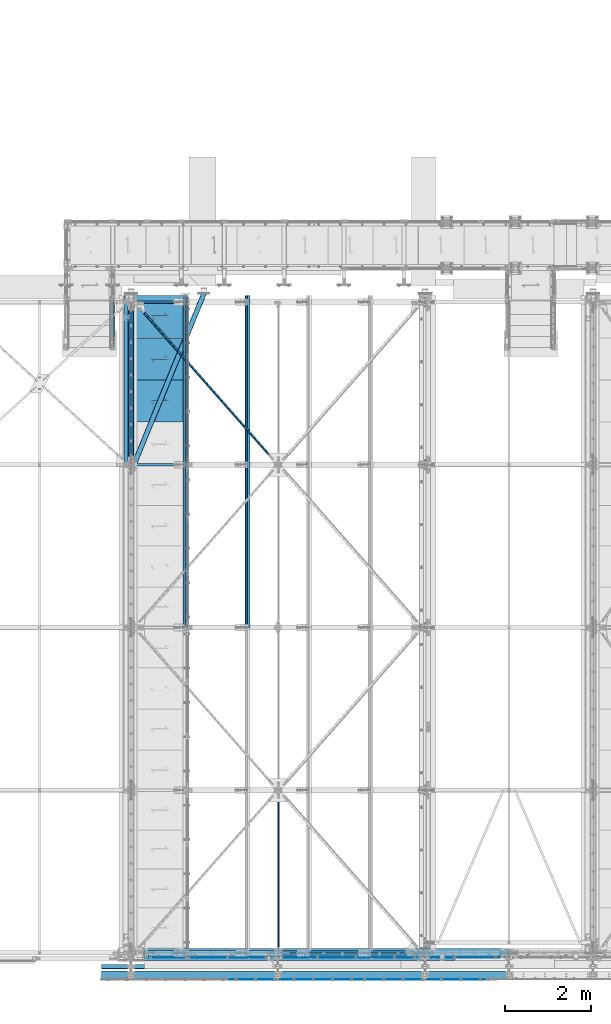
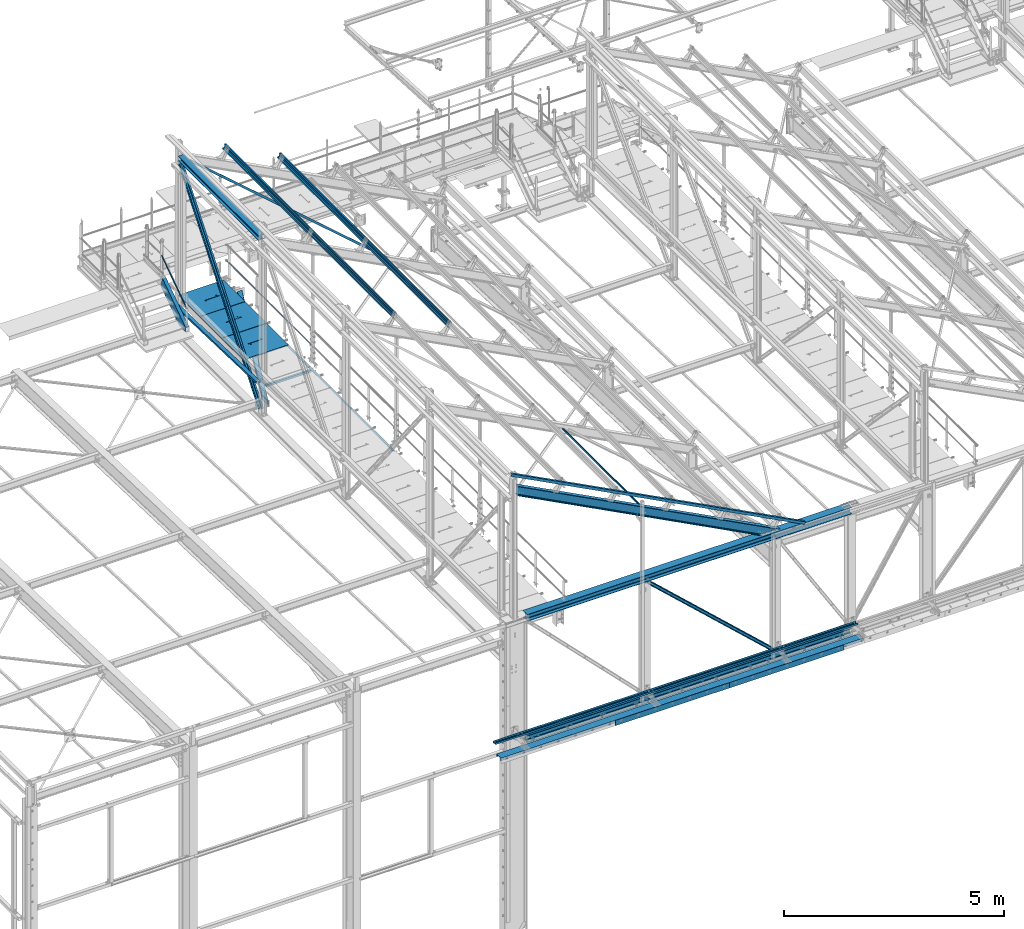
# One storey, part 46 of 496: 22 beams, 8 members, 30 elements without a shape of their own.
"""IFC2X3 building model written with IfcOpenShell, lengths in millimetres."""

from ifc_helpers import new_model, si_unit, frame, origin_with_axes, origin_2d_with_axis, place, context, subcontext, project, spatial, polyline, rectangle, hollow_rectangle, hollow_circle, i_section, l_section, u_section, outline, extrude, boolean, clip, halfspace, material, type_object, element, aggregate, save


model = new_model("IFC2X3")

# Units and contexts
model_context = context("Model", 3, precision=1e-05, world=origin_with_axes())
body_context = subcontext(model_context, "Body", "Model", "MODEL_VIEW")
ifc_project = project(units=[si_unit("LENGTHUNIT", "METRE", prefix="MILLI"), si_unit("AREAUNIT", "SQUARE_METRE"), si_unit("VOLUMEUNIT", "CUBIC_METRE"), si_unit("MASSUNIT", "GRAM", prefix="KILO"), si_unit("TIMEUNIT", "SECOND"), si_unit("PLANEANGLEUNIT", "RADIAN"), si_unit("SOLIDANGLEUNIT", "STERADIAN"), si_unit("THERMODYNAMICTEMPERATUREUNIT", "DEGREE_CELSIUS"), si_unit("LUMINOUSINTENSITYUNIT", "LUMEN")], contexts=[model_context])

# Site, building, storey
site_placement = place(None, origin_with_axes())
site = spatial("IfcSite", under=ifc_project, at=site_placement, CompositionType="ELEMENT")
building_placement = place(site_placement, origin_with_axes())
building = spatial("IfcBuilding", under=site, at=building_placement, Name="Undefined", CompositionType="ELEMENT")
storey_placement = place(building_placement, origin_with_axes())
storey = spatial("IfcBuildingStorey", under=building, at=storey_placement, Name="Undefined", CompositionType="ELEMENT", Elevation=0.0)

# Assembly, member
assembly_1_placement = place(storey_placement, origin_with_axes())
assembly_1 = element("IfcElementAssembly", 1, at=assembly_1_placement, inside=storey, Name="MAIN COURANTE", AssemblyPlace="NOTDEFINED", PredefinedType="NOTDEFINED")
ifc_material_1 = material(Name="Undefined/S235-E24")
member_type_1 = type_object("IfcMemberType", PredefinedType="NOTDEFINED")
member_1_placement = place(assembly_1_placement, frame((12269.9936634988, 14144.9998536997, 8651.13839395851), z_axis=(0.999999999999672, -6.66011674184119e-07, -4.61008081401814e-07), x_axis=(0.0, 0.822192191679776, 0.569209978778312)))
member_1 = element("IfcMember", 2, at=member_1_placement, type_object=member_type_1, material=ifc_material_1, Name="LISSE", context=body_context, shape_type="Clipping", body=[
    clip(clip(extrude(hollow_circle(Radius=10.64999962, WallThickness=2.0, at=origin_2d_with_axis()), frame((1395.35433691202, -1.13686837721616e-12, 7.38694435286663e-20), z_axis=(-1.0, 0.0, 0.0), x_axis=(0.0, -1.0, 0.0)), (0.0, 0.0, 1.0), 1404.17), halfspace(frame((1387.78549896895, 10.5802584847568, -0.00112410556903342), z_axis=(-0.822192191679508, 0.569209978778309, 6.66011673795452e-07), x_axis=(-0.569209978778123, -0.822192191679778, 4.61008086858783e-07)), True)), halfspace(frame((16.4615054726892, 14.9935154708171, -1.33328576339409e-05), z_axis=(0.822192191679509, -0.569209978778308, -6.66011673277761e-07), x_axis=(0.0, 0.0, -1.0)), True)),
])
aggregate(assembly_1, [member_1])

# Assembly, beam
assembly_2_placement = place(storey_placement, origin_with_axes())
assembly_2 = element("IfcElementAssembly", 3, at=assembly_2_placement, inside=storey, Name="SUPPORT", AssemblyPlace="NOTDEFINED", PredefinedType="NOTDEFINED")
beam_type_1 = type_object("IfcBeamType", PredefinedType="NOTDEFINED")
beam_1_placement = place(assembly_2_placement, frame((13921.4998855121, 15280.0000894508, 8074.99999999999), z_axis=(-1.0, 0.0, 0.0), x_axis=(0.0, -1.0, 0.0)))
beam_1 = element("IfcBeam", 4, at=beam_1_placement, type_object=beam_type_1, material=ifc_material_1, Name="SUPPORT", context=body_context, shape_type="SweptSolid", body=[
    extrude(l_section(Depth=50.0, Width=50.0, Thickness=5.0, FilletRadius=7.0, EdgeRadius=3.5, at=origin_2d_with_axis()), frame((7675.0000889974, 0.0, 0.0), z_axis=(-1.0, 0.0, 0.0), x_axis=(0.0, -1.0, 0.0)), (0.0, 0.0, 1.0), 7675.0),
])
aggregate(assembly_2, [beam_1])

# Assembly, member
assembly_3_placement = place(storey_placement, origin_with_axes())
assembly_3 = element("IfcElementAssembly", 5, at=assembly_3_placement, inside=storey, AssemblyPlace="NOTDEFINED", PredefinedType="NOTDEFINED")
ifc_material_2 = material(Name="Undefined/S275-E28")
member_type_2 = type_object("IfcMemberType", Name="UPN260", PredefinedType="NOTDEFINED")
member_2_placement = place(assembly_3_placement, frame((12254.9957050653, 15220.1081967775, 8803.11488296132), z_axis=(-2.38199999876088e-06, 0.569209978780056, -0.822192191675118), x_axis=(-8.09999997507615e-07, -0.822192191679509, -0.569209978778121)))
member_2 = element("IfcMember", 6, at=member_2_placement, type_object=member_type_2, material=ifc_material_2, ObjectType="UPN260", context=body_context, shape_type="Clipping", body=[
    clip(clip(clip(extrude(u_section(Depth=260.0, FlangeWidth=90.0, WebThickness=10.0, FlangeThickness=14.0, FilletRadius=14.0, EdgeRadius=7.0, FlangeSlope=0.0798299857122373, at=origin_2d_with_axis()), frame((1532.05974941516, 3.24426271229202e-19, 1.50656932765752e-12), z_axis=(-1.0, 0.0, 0.0), x_axis=(0.0, -1.0, 0.0)), (0.0, 0.0, 1.0), 1652.65), halfspace(frame((1475.10561376755, -44.9999999999982, -130.0), z_axis=(0.594754891759256, -2.93590080272386e-06, 0.803907095826263), x_axis=(-0.803907095829728, -3.97667463540568e-10, 0.594754891761819)), False)), halfspace(frame((1280.85769771495, 106.407624448384, -129.999853684547), z_axis=(-0.822192191678566, 5.58458236969981e-08, 0.569209978780058), x_axis=(0.569209978777471, -2.93579533354204e-06, 0.822192191675117)), True)), halfspace(frame((81.2187427422505, 545.001446996483, 130.001191003446), z_axis=(0.954513538741863, -9.28664575673263e-07, -0.298167577643218), x_axis=(1.71699999918928e-06, 0.999999999995689, 2.38199999876088e-06)), True)),
])
aggregate(assembly_3, [member_2])

# Assembly, beam
assembly_4_placement = place(storey_placement, origin_with_axes())
assembly_4 = element("IfcElementAssembly", 7, at=assembly_4_placement, inside=storey, AssemblyPlace="NOTDEFINED", PredefinedType="NOTDEFINED")
beam_type_2 = type_object("IfcBeamType", PredefinedType="NOTDEFINED")
beam_2_placement = place(assembly_4_placement, frame((12780.6286044855, 15197.8852381123, 12052.4067909321), z_axis=(0.628485342577473, 0.704921080203063, -0.328774154778966), x_axis=(0.624617904868394, -0.709285746850553, -0.32675097893116)))
beam_2 = element("IfcBeam", 8, at=beam_2_placement, type_object=beam_type_2, material=ifc_material_1, context=body_context, shape_type="Clipping", body=[
    clip(clip(extrude(l_section(Depth=60.0, Width=60.0, Thickness=6.0, FilletRadius=8.0, EdgeRadius=4.0, at=origin_2d_with_axis()), frame((5268.62284058304, 0.0, -2.92467319284064e-13), z_axis=(-1.0, 0.0, 0.0), x_axis=(0.0, -1.0, 0.0)), (0.0, 0.0, 1.0), 5179.74), halfspace(frame((5188.72404710403, 30.0000006031805, -30.0000000072323), z_axis=(1.0, 0.0, 0.0), x_axis=(0.0, -1.0, 0.0)), False)), halfspace(frame((168.778125634137, 30.0000272725665, 30.0000000280488), z_axis=(-1.0, 0.0, 0.0), x_axis=(0.0, -1.0, 0.0)), False)),
])
aggregate(assembly_4, [beam_2])

assembly_5_placement = place(storey_placement, origin_with_axes())
assembly_5 = element("IfcElementAssembly", 9, at=assembly_5_placement, inside=storey, Name="SUPPORT", AssemblyPlace="NOTDEFINED", PredefinedType="NOTDEFINED")
beam_type_3 = type_object("IfcBeamType", PredefinedType="NOTDEFINED")
beam_3_placement = place(assembly_5_placement, frame((17989.9999880566, -622.0, 5154.99824538435), z_axis=(0.0, 0.0, 1.0), x_axis=(1.0, 0.0, 0.0)))
beam_3 = element("IfcBeam", 10, at=beam_3_placement, type_object=beam_type_3, material=ifc_material_1, Name="SUPPORT", context=body_context, shape_type="SweptSolid", body=[
    extrude(rectangle(XDim=4.0, YDim=150.0, at=origin_2d_with_axis()), frame((2999.99999402831, 0.0, 0.0), z_axis=(-1.0, 0.0, 0.0), x_axis=(0.0, -1.0, 0.0)), (0.0, 0.0, 1.0), 3000.0),
])
aggregate(assembly_5, [beam_3])

assembly_6_placement = place(storey_placement, origin_with_axes())
assembly_6 = element("IfcElementAssembly", 11, at=assembly_6_placement, inside=storey, Name="SUPPORT", AssemblyPlace="NOTDEFINED", PredefinedType="NOTDEFINED")
beam_4_placement = place(assembly_6_placement, frame((14989.9999940283, -622.0, 5154.99824538435), z_axis=(0.0, 0.0, 1.0), x_axis=(1.0, 0.0, 0.0)))
beam_4 = element("IfcBeam", 12, at=beam_4_placement, type_object=beam_type_3, material=ifc_material_1, Name="SUPPORT", context=body_context, shape_type="SweptSolid", body=[
    extrude(rectangle(XDim=4.0, YDim=150.0, at=origin_2d_with_axis()), frame((2999.99999402831, 0.0, 0.0), z_axis=(-1.0, 0.0, 0.0), x_axis=(0.0, -1.0, 0.0)), (0.0, 0.0, 1.0), 3000.0),
])
aggregate(assembly_6, [beam_4])

assembly_7_placement = place(storey_placement, origin_with_axes())
assembly_7 = element("IfcElementAssembly", 13, at=assembly_7_placement, inside=storey, Name="SUPPORT", AssemblyPlace="NOTDEFINED", PredefinedType="NOTDEFINED")
beam_type_4 = type_object("IfcBeamType", PredefinedType="NOTDEFINED")
beam_5_placement = place(assembly_7_placement, frame((21504.9999940283, -320.0, 5474.99824538435), z_axis=(0.0, -1.0, 0.0), x_axis=(-1.0, 0.0, 0.0)))
beam_5 = element("IfcBeam", 14, at=beam_5_placement, type_object=beam_type_4, material=ifc_material_1, Name="SUPPORT", context=body_context, shape_type="SweptSolid", body=[
    extrude(u_section(Depth=100.0, FlangeWidth=50.0, WebThickness=4.0, FlangeThickness=4.0, at=origin_2d_with_axis()), frame((9514.99999402831, 0.0, 0.0), z_axis=(-1.0, 0.0, 0.0), x_axis=(0.0, -1.0, 0.0)), (0.0, 0.0, 1.0), 9515.0),
])
aggregate(assembly_7, [beam_5])

assembly_8_placement = place(storey_placement, origin_with_axes())
assembly_8 = element("IfcElementAssembly", 15, at=assembly_8_placement, inside=storey, Name="LISSE", AssemblyPlace="NOTDEFINED", PredefinedType="NOTDEFINED")
beam_6_placement = place(assembly_8_placement, frame((12563.5000000142, 11402.9585391484, 8171.89575101457), z_axis=(1.0, 0.0, 0.0), x_axis=(0.0, 0.999506445341009, -0.0314144190107172)))
beam_6 = element("IfcBeam", 16, at=beam_6_placement, type_object=beam_type_4, material=ifc_material_1, Name="LISSE", context=body_context, shape_type="Clipping", body=[
    clip(extrude(u_section(Depth=100.0, FlangeWidth=50.0, WebThickness=4.0, FlangeThickness=4.0, at=origin_2d_with_axis()), frame((3989.01014791664, 0.0, 0.0), z_axis=(-1.0, 0.0, 0.0), x_axis=(0.0, -1.0, 0.0)), (0.0, 0.0, 1.0), 3989.01), halfspace(frame((3959.78106204689, -24.99999999994, -50.0), z_axis=(0.999506472307554, 0.0314135610096964, 0.0), x_axis=(0.0, 0.0, 1.0)), False)),
])
aggregate(assembly_8, [beam_6])

assembly_9_placement = place(storey_placement, origin_with_axes())
assembly_9 = element("IfcElementAssembly", 17, at=assembly_9_placement, inside=storey, Name="SUPPORT", AssemblyPlace="NOTDEFINED", PredefinedType="NOTDEFINED")
beam_type_5 = type_object("IfcBeamType", Name="UPN200", PredefinedType="NOTDEFINED")
beam_7_placement = place(assembly_9_placement, frame((11990.0, -520.0, 5192.49824538435), z_axis=(0.0, -1.0, 0.0), x_axis=(1.0, 0.0, 0.0)))
beam_7 = element("IfcBeam", 18, at=beam_7_placement, type_object=beam_type_5, material=ifc_material_2, Name="SUPPORT", ObjectType="UPN200", context=body_context, shape_type="SweptSolid", body=[
    extrude(u_section(Depth=200.0, FlangeWidth=75.0, WebThickness=8.5, FlangeThickness=11.5, FilletRadius=11.5, EdgeRadius=6.0, FlangeSlope=0.0798299857122373, at=origin_2d_with_axis()), frame((9514.99999402831, 0.0, 0.0), z_axis=(-1.0, 0.0, 0.0), x_axis=(0.0, -1.0, 0.0)), (0.0, 0.0, 1.0), 9515.0),
])
aggregate(assembly_9, [beam_7])

assembly_10_placement = place(storey_placement, origin_with_axes())
assembly_10 = element("IfcElementAssembly", 19, at=assembly_10_placement, inside=storey, Name="SUPPORT", AssemblyPlace="NOTDEFINED", PredefinedType="NOTDEFINED")
beam_type_6 = type_object("IfcBeamType", PredefinedType="NOTDEFINED")
beam_8_placement = place(assembly_10_placement, frame((13095.0012593194, -105.0, 5040.00085614788), z_axis=(0.0, 0.0, 1.0), x_axis=(1.0, 0.0, 0.0)))
beam_8 = element("IfcBeam", 20, at=beam_8_placement, type_object=beam_type_6, material=ifc_material_1, Name="SUPPORT", context=body_context, shape_type="SweptSolid", body=[
    extrude(rectangle(XDim=10.0, YDim=80.0, at=origin_2d_with_axis()), frame((8194.99874155635, -2.1691981052518e-19, 0.0), z_axis=(-1.0, 0.0, 0.0), x_axis=(0.0, -1.0, 0.0)), (0.0, 0.0, 1.0), 8195.0),
])
aggregate(assembly_10, [beam_8])

assembly_11_placement = place(storey_placement, origin_with_axes())
assembly_11 = element("IfcElementAssembly", 21, at=assembly_11_placement, inside=storey, AssemblyPlace="NOTDEFINED", PredefinedType="NOTDEFINED")
beam_type_7 = type_object("IfcBeamType", PredefinedType="NOTDEFINED")
beam_9_placement = place(assembly_11_placement, frame((13936.4998764003, 15354.9999809229, 8115.0), z_axis=(0.0, 0.0, 1.0), x_axis=(-1.0, 0.0, 0.0)))
beam_9 = element("IfcBeam", 22, at=beam_9_placement, type_object=beam_type_7, material=ifc_material_1, context=body_context, shape_type="CSG", body=[
    boolean("DIFFERENCE", extrude(outline(polyline([(0.0, 0.0), (1179.99169921875, 0.0), (1179.99169921875, 980.0), (-9.39995516091585e-07, 980.0), (0.0, 0.0)])), frame((0.0, 0.0, -15.0), z_axis=(0.0, 0.0, 1.0), x_axis=(1.0, 0.0, 0.0)), (0.0, 0.0, 1.0), 30.0), extrude(outline(polyline([(0.0, 0.0), (9.99999999997453, 6.91215973347425e-11), (10.0000000004329, 75.8578643791443), (282.842712400121, -196.984848017997), (282.842712400743, -96.9848480190813), (272.842712400776, -96.9848480191613), (272.842712400299, -172.842712398218), (0.0, 100.0), (0.0, 0.0)])), frame((724.286946489367, 555.710676888644, -17.5), z_axis=(0.0, 0.0, 1.0), x_axis=(-0.707106781186457, -0.707106781186639, 0.0)), (0.0, 0.0, 1.0), 35.0)),
])
aggregate(assembly_11, [beam_9])

assembly_12_placement = place(storey_placement, origin_with_axes())
assembly_12 = element("IfcElementAssembly", 23, at=assembly_12_placement, inside=storey, AssemblyPlace="NOTDEFINED", PredefinedType="NOTDEFINED")
beam_10_placement = place(assembly_12_placement, frame((13936.4998764003, 14364.9999856922, 8115.0), z_axis=(0.0, 0.0, 1.0), x_axis=(-1.0, 0.0, 0.0)))
beam_10 = element("IfcBeam", 24, at=beam_10_placement, type_object=beam_type_7, material=ifc_material_1, context=body_context, shape_type="CSG", body=[
    boolean("DIFFERENCE", extrude(outline(polyline([(0.0, 0.0), (1179.99169921875, 0.0), (1179.99169921875, 980.0), (-9.39995516091585e-07, 980.0), (0.0, 0.0)])), frame((0.0, 0.0, -15.0), z_axis=(0.0, 0.0, 1.0), x_axis=(1.0, 0.0, 0.0)), (0.0, 0.0, 1.0), 30.0), extrude(outline(polyline([(0.0, 0.0), (9.99999999997453, 6.91215973347425e-11), (10.0000000004329, 75.8578643791443), (282.842712400121, -196.984848017997), (282.842712400743, -96.9848480190813), (272.842712400776, -96.9848480191613), (272.842712400299, -172.842712398218), (0.0, 100.0), (0.0, 0.0)])), frame((724.286946489367, 555.710676888644, -17.5), z_axis=(0.0, 0.0, 1.0), x_axis=(-0.707106781186457, -0.707106781186639, 0.0)), (0.0, 0.0, 1.0), 35.0)),
])
aggregate(assembly_12, [beam_10])

assembly_13_placement = place(storey_placement, origin_with_axes())
assembly_13 = element("IfcElementAssembly", 25, at=assembly_13_placement, inside=storey, AssemblyPlace="NOTDEFINED", PredefinedType="NOTDEFINED")
beam_11_placement = place(assembly_13_placement, frame((13936.4998764003, 13374.9999904615, 8115.0), z_axis=(0.0, 0.0, 1.0), x_axis=(-1.0, 0.0, 0.0)))
beam_11 = element("IfcBeam", 26, at=beam_11_placement, type_object=beam_type_7, material=ifc_material_1, context=body_context, shape_type="CSG", body=[
    boolean("DIFFERENCE", extrude(outline(polyline([(0.0, 0.0), (1179.99169921875, 0.0), (1179.99169921875, 980.0), (-9.39995516091585e-07, 980.0), (0.0, 0.0)])), frame((0.0, 0.0, -15.0), z_axis=(0.0, 0.0, 1.0), x_axis=(1.0, 0.0, 0.0)), (0.0, 0.0, 1.0), 30.0), extrude(outline(polyline([(0.0, 0.0), (9.99999999997453, 6.91215973347425e-11), (10.0000000004329, 75.8578643791443), (282.842712400121, -196.984848017997), (282.842712400743, -96.9848480190813), (272.842712400776, -96.9848480191613), (272.842712400299, -172.842712398218), (0.0, 100.0), (0.0, 0.0)])), frame((724.286946489367, 555.710676888644, -17.5), z_axis=(0.0, 0.0, 1.0), x_axis=(-0.707106781186457, -0.707106781186639, 0.0)), (0.0, 0.0, 1.0), 35.0)),
])
aggregate(assembly_13, [beam_11])

assembly_14_placement = place(storey_placement, origin_with_axes())
assembly_14 = element("IfcElementAssembly", 27, at=assembly_14_placement, inside=storey, Name="SUPPORT", AssemblyPlace="NOTDEFINED", PredefinedType="NOTDEFINED")
beam_type_8 = type_object("IfcBeamType", PredefinedType="NOTDEFINED")
beam_12_placement = place(assembly_14_placement, frame((13095.0012649032, -64.9984779165766, 5045.00085614788), z_axis=(0.0, 1.0, 0.0), x_axis=(1.0, 0.0, 0.0)))
beam_12 = element("IfcBeam", 28, at=beam_12_placement, type_object=beam_type_8, material=ifc_material_1, Name="SUPPORT", context=body_context, shape_type="SweptSolid", body=[
    extrude(l_section(Depth=70.0, Width=70.0, Thickness=7.0, FilletRadius=9.0, EdgeRadius=4.5, at=origin_2d_with_axis()), frame((8194.99874155635, -2.1691981052518e-19, 0.0), z_axis=(-1.0, 0.0, 0.0), x_axis=(0.0, -1.0, 0.0)), (0.0, 0.0, 1.0), 8195.0),
])
aggregate(assembly_14, [beam_12])

assembly_15_placement = place(storey_placement, origin_with_axes())
assembly_15 = element("IfcElementAssembly", 29, at=assembly_15_placement, inside=storey, Name="MAIN COURANTE", AssemblyPlace="NOTDEFINED", PredefinedType="NOTDEFINED")
beam_type_9 = type_object("IfcBeamType", PredefinedType="NOTDEFINED")
beam_13_placement = place(assembly_15_placement, frame((13993.9998937557, 15300.0034477439, 8673.79999660984), z_axis=(0.0, 0.0, 1.0), x_axis=(0.0, -1.0, 0.0)))
beam_13 = element("IfcBeam", 30, at=beam_13_placement, type_object=beam_type_9, material=ifc_material_1, Name="LISSE", context=body_context, shape_type="SweptSolid", body=[
    extrude(hollow_circle(Radius=13.44999981, WallThickness=2.0, at=origin_2d_with_axis()), frame((3845.0034383235, -7.91283071904719e-22, 7.95128074845232e-22), z_axis=(-1.0, 0.0, 0.0), x_axis=(0.0, -1.0, 0.0)), (0.0, 0.0, 1.0), 3845.0),
])
aggregate(assembly_15, [beam_13])

assembly_16_placement = place(storey_placement, origin_with_axes())
assembly_16 = element("IfcElementAssembly", 31, at=assembly_16_placement, inside=storey, AssemblyPlace="NOTDEFINED", PredefinedType="NOTDEFINED")
beam_type_10 = type_object("IfcBeamType", PredefinedType="NOTDEFINED")
beam_14_placement = place(assembly_16_placement, frame((16124.270567048, 3720.00159576188, 10291.9905320581), z_axis=(-0.886082013248113, 9.38091927309869e-07, 0.463528495129794), x_axis=(0.0, -1.0, 0.0)))
beam_14 = element("IfcBeam", 32, at=beam_14_placement, type_object=beam_type_10, material=ifc_material_1, context=body_context, shape_type="SweptSolid", body=[
    extrude(hollow_rectangle(XDim=40.0, YDim=40.0, WallThickness=4.0, InnerFilletRadius=4.0, OuterFilletRadius=8.0, at=origin_2d_with_axis()), frame((3700.00159576542, -3.63797880709171e-12, -3.63797880709171e-12), z_axis=(-1.0, 0.0, 0.0), x_axis=(0.0, -1.0, 0.0)), (0.0, 0.0, 1.0), 3700.0),
])
aggregate(assembly_16, [beam_14])

assembly_17_placement = place(storey_placement, origin_with_axes())
assembly_17 = element("IfcElementAssembly", 33, at=assembly_17_placement, inside=storey, AssemblyPlace="NOTDEFINED", PredefinedType="NOTDEFINED")
beam_type_11 = type_object("IfcBeamType", Name="HEA140", PredefinedType="NOTDEFINED")
beam_15_placement = place(assembly_17_placement, frame((12683.5, 15125.0, 12103.5), z_axis=(0.0, 0.0, 1.0), x_axis=(0.0, -1.0, 0.0)))
beam_15 = element("IfcBeam", 34, at=beam_15_placement, type_object=beam_type_11, material=ifc_material_2, ObjectType="HEA140", context=body_context, shape_type="SweptSolid", body=[
    extrude(i_section(OverallWidth=140.0, OverallDepth=133.0, WebThickness=5.5, FlangeThickness=8.5, FilletRadius=12.0, at=origin_2d_with_axis()), frame((3650.0, 0.0, 0.0), z_axis=(-1.0, 0.0, 0.0), x_axis=(0.0, -1.0, 0.0)), (0.0, 0.0, 1.0), 3650.0),
])
aggregate(assembly_17, [beam_15])

assembly_18_placement = place(storey_placement, origin_with_axes())
assembly_18 = element("IfcElementAssembly", 35, at=assembly_18_placement, inside=storey, Name="TRAVERSE HAUTE", AssemblyPlace="NOTDEFINED", PredefinedType="NOTDEFINED")
beam_type_12 = type_object("IfcBeamType", Name="HEA200", PredefinedType="NOTDEFINED")
beam_16_placement = place(assembly_18_placement, frame((21504.9998412122, 0.0, 8454.99483451416), z_axis=(0.0, 0.0, -1.0), x_axis=(-1.0, 0.0, 0.0)))
beam_16 = element("IfcBeam", 36, at=beam_16_placement, type_object=beam_type_12, material=ifc_material_2, Name="TRAVERSE HAUTE", ObjectType="HEA200", context=body_context, shape_type="SweptSolid", body=[
    extrude(i_section(OverallWidth=200.0, OverallDepth=190.0, WebThickness=6.5, FlangeThickness=10.0, FilletRadius=18.0, at=origin_2d_with_axis()), frame((8514.99984646966, 0.0, -5.63475423111337e-20), z_axis=(-1.0, 0.0, 0.0), x_axis=(0.0, -1.0, 0.0)), (0.0, 0.0, 1.0), 8515.0),
])
aggregate(assembly_18, [beam_16])

assembly_19_placement = place(storey_placement, origin_with_axes())
assembly_19 = element("IfcElementAssembly", 37, at=assembly_19_placement, inside=storey, Name="TRAVERSE BASSE", AssemblyPlace="NOTDEFINED", PredefinedType="NOTDEFINED")
beam_17_placement = place(assembly_19_placement, frame((12990.0000051835, 0.0, 5095.00085614788), z_axis=(0.0, 0.0, 1.0), x_axis=(1.0, 0.0, 0.0)))
beam_17 = element("IfcBeam", 38, at=beam_17_placement, type_object=beam_type_12, material=ifc_material_2, Name="TRAVERSE BASSE", ObjectType="HEA200", context=body_context, shape_type="SweptSolid", body=[
    extrude(i_section(OverallWidth=200.0, OverallDepth=190.0, WebThickness=6.5, FlangeThickness=10.0, FilletRadius=18.0, at=origin_2d_with_axis()), frame((8514.99984646966, 0.0, -5.63475423111337e-20), z_axis=(-1.0, 0.0, 0.0), x_axis=(0.0, -1.0, 0.0)), (0.0, 0.0, 1.0), 8515.0),
])
aggregate(assembly_19, [beam_17])

assembly_20_placement = place(storey_placement, origin_with_axes())
assembly_20 = element("IfcElementAssembly", 39, at=assembly_20_placement, inside=storey, Name="SHED", AssemblyPlace="NOTDEFINED", PredefinedType="NOTDEFINED")
beam_type_13 = type_object("IfcBeamType", PredefinedType="NOTDEFINED")
beam_18_placement = place(assembly_20_placement, frame((13958.9855132914, 7605.00007961586, 11830.9803799265), z_axis=(0.46352885499701, 6.99999093634976e-09, 0.886081824994261), x_axis=(0.0, 1.0, 0.0)))
beam_18 = element("IfcBeam", 40, at=beam_18_placement, type_object=beam_type_13, material=ifc_material_1, Name="SHED", context=body_context, shape_type="SweptSolid", body=[
    extrude(outline(polyline([(-27.9999999860338, 36.0000000101354), (-27.999999986052, 70.0000000101354), (28.0000000138389, 70.0000000101209), (28.0000000138425, 58.0000000101209), (26.5000000138534, 58.0000000101209), (26.5000000138352, 68.5000000101172), (-26.4999999860593, 68.5000000101354), (-26.4999999860338, 36.7000007730749), (-1.49999998607018, 15.6999998194005), (-1.49999998605563, -15.6999997991297), (-26.4999999859974, -36.7000007527895), (-26.4999999859829, -68.49999998985), (26.5000000139153, -68.4999999898646), (26.500000013908, -57.9999999898646), (28.0000000139116, -57.9999999898646), (28.0000000139153, -69.9999999898646), (-27.9999999859756, -69.99999998985), (-27.9999999859901, -35.99999998985), (-2.99999998605927, -14.9999999898646), (-2.9999999860629, 15.0000000101354), (-27.9999999860338, 36.0000000101354)])), frame((7750.00000000006, -3.63797880548905e-12, 0.0), z_axis=(-1.0, 0.0, 0.0), x_axis=(0.0, -1.0, 0.0)), (0.0, 0.0, 1.0), 7750.0),
])
aggregate(assembly_20, [beam_18])

assembly_21_placement = place(storey_placement, origin_with_axes())
assembly_21 = element("IfcElementAssembly", 41, at=assembly_21_placement, inside=storey, Name="SHED", AssemblyPlace="NOTDEFINED", PredefinedType="NOTDEFINED")
beam_19_placement = place(assembly_21_placement, frame((15396.285514181, 7605.00007961586, 11079.0980100134), z_axis=(0.46352885499701, 6.99999093634976e-09, 0.886081824994261), x_axis=(0.0, 1.0, 0.0)))
beam_19 = element("IfcBeam", 42, at=beam_19_placement, type_object=beam_type_13, material=ifc_material_1, Name="SHED", context=body_context, shape_type="SweptSolid", body=[
    extrude(outline(polyline([(-27.9999999860338, 36.0000000101354), (-27.999999986052, 70.0000000101354), (28.0000000138389, 70.0000000101209), (28.0000000138425, 58.0000000101209), (26.5000000138534, 58.0000000101209), (26.5000000138352, 68.5000000101172), (-26.4999999860593, 68.5000000101354), (-26.4999999860338, 36.7000007730749), (-1.49999998607018, 15.6999998194005), (-1.49999998605563, -15.6999997991297), (-26.4999999859974, -36.7000007527895), (-26.4999999859829, -68.49999998985), (26.5000000139153, -68.4999999898646), (26.500000013908, -57.9999999898646), (28.0000000139116, -57.9999999898646), (28.0000000139153, -69.9999999898646), (-27.9999999859756, -69.99999998985), (-27.9999999859901, -35.99999998985), (-2.99999998605927, -14.9999999898646), (-2.9999999860629, 15.0000000101354), (-27.9999999860338, 36.0000000101354)])), frame((7750.00000000006, -3.63797880548905e-12, 0.0), z_axis=(-1.0, 0.0, 0.0), x_axis=(0.0, -1.0, 0.0)), (0.0, 0.0, 1.0), 7750.0),
])
aggregate(assembly_21, [beam_19])

# Assembly, member
assembly_22_placement = place(storey_placement, origin_with_axes())
assembly_22 = element("IfcElementAssembly", 43, at=assembly_22_placement, inside=storey, AssemblyPlace="NOTDEFINED", PredefinedType="NOTDEFINED")
member_type_3 = type_object("IfcMemberType", PredefinedType="NOTDEFINED")
member_3_placement = place(assembly_22_placement, frame((12520.1676065385, -145.0, 12631.0564639226), z_axis=(-0.463528461042168, 0.0, -0.886082031080576), x_axis=(0.886081856298361, 3.500000375794e-08, -0.463528795156082)))
member_3 = element("IfcMember", 44, at=member_3_placement, type_object=member_type_3, material=ifc_material_1, context=body_context, shape_type="SweptSolid", body=[
    extrude(l_section(Depth=70.0, Width=70.0, Thickness=7.0, FilletRadius=9.0, EdgeRadius=4.5, at=origin_2d_with_axis()), frame((8699.9969717581, 0.0, 0.0), z_axis=(-1.0, 0.0, 0.0), x_axis=(0.0, -1.0, 0.0)), (0.0, 0.0, 1.0), 8700.0),
])
aggregate(assembly_22, [member_3])

assembly_23_placement = place(storey_placement, origin_with_axes())
assembly_23 = element("IfcElementAssembly", 45, at=assembly_23_placement, inside=storey, AssemblyPlace="NOTDEFINED", PredefinedType="NOTDEFINED")
member_type_4 = type_object("IfcMemberType", Name="UPN80", PredefinedType="NOTDEFINED")
member_4_placement = place(assembly_23_placement, frame((12707.5000000297, 11400.0000000125, 7249.99999999999), z_axis=(0.0, -0.783225668198107, 0.621737527157264), x_axis=(0.0, 0.621737534986566, 0.783225661983077)))
member_4 = element("IfcMember", 46, at=member_4_placement, type_object=member_type_4, material=ifc_material_2, ObjectType="UPN80", context=body_context, shape_type="Clipping", body=[
    clip(clip(extrude(u_section(Depth=80.0, FlangeWidth=45.0, WebThickness=6.0, FlangeThickness=8.0, FilletRadius=8.0, EdgeRadius=4.0, FlangeSlope=0.0798299857122373, at=origin_2d_with_axis()), frame((6070.59674052178, 0.0, 0.0), z_axis=(-1.0, 0.0, 0.0), x_axis=(0.0, -1.0, 0.0)), (0.0, 0.0, 1.0), 6029.29), halfspace(frame((5991.90387685635, 27.5000000297259, -40.0000004439507), z_axis=(-1.0, 0.0, 0.0), x_axis=(0.0, 1.0, 0.0)), True)), halfspace(frame((119.999999989826, 27.5000000297296, 39.9999985196016), z_axis=(1.0, 0.0, 0.0), x_axis=(0.0, 1.0, 0.0)), True)),
])
aggregate(assembly_23, [member_4])

assembly_24_placement = place(storey_placement, origin_with_axes())
assembly_24 = element("IfcElementAssembly", 47, at=assembly_24_placement, inside=storey, AssemblyPlace="NOTDEFINED", PredefinedType="NOTDEFINED")
member_5_placement = place(assembly_24_placement, frame((12652.5000000316, 15200.0000000035, 12037.0), z_axis=(0.0, -0.783225668198107, 0.621737527157264), x_axis=(0.0, -0.621737527157263, -0.783225668198107)))
member_5 = element("IfcMember", 48, at=member_5_placement, type_object=member_type_4, material=ifc_material_2, ObjectType="UPN80", context=body_context, shape_type="Clipping", body=[
    clip(clip(extrude(u_section(Depth=80.0, FlangeWidth=45.0, WebThickness=6.0, FlangeThickness=8.0, FilletRadius=8.0, EdgeRadius=4.0, FlangeSlope=0.0798299857122373, at=origin_2d_with_axis()), frame((6070.59674052178, 0.0, 0.0), z_axis=(-1.0, 0.0, 0.0), x_axis=(0.0, -1.0, 0.0)), (0.0, 0.0, 1.0), 6029.29), halfspace(frame((5991.90387686459, 27.4999999683569, 39.9999999999964), z_axis=(-1.0, 0.0, 0.0), x_axis=(0.0, -1.0, 0.0)), True)), halfspace(frame((119.999999997919, 27.49999999375, -39.9999989691296), z_axis=(1.0, 0.0, 0.0), x_axis=(0.0, -1.0, 0.0)), True)),
])
aggregate(assembly_24, [member_5])

assembly_25_placement = place(storey_placement, origin_with_axes())
assembly_25 = element("IfcElementAssembly", 49, at=assembly_25_placement, inside=storey, AssemblyPlace="NOTDEFINED", PredefinedType="NOTDEFINED")
member_6_placement = place(assembly_25_placement, frame((16114.9998359816, 27.5000000049731, 8359.99931169984), z_axis=(-0.678191069310477, 0.0, -0.734885619336446), x_axis=(0.734885639959882, 0.0, -0.678191046962989)))
member_6 = element("IfcMember", 50, at=member_6_placement, type_object=member_type_4, material=ifc_material_2, ObjectType="UPN80", context=body_context, shape_type="Clipping", body=[
    clip(clip(extrude(u_section(Depth=80.0, FlangeWidth=45.0, WebThickness=6.0, FlangeThickness=8.0, FilletRadius=8.0, EdgeRadius=4.0, FlangeSlope=0.0798299857122373, at=origin_2d_with_axis()), frame((4634.7372696759, -7.105427357601e-15, -3.38069920559759e-12), z_axis=(-1.0, 0.0, 0.0), x_axis=(0.0, -1.0, 0.0)), (0.0, 0.0, 1.0), 4595.28), halfspace(frame((4554.19698295392, 27.5000000049731, -40.0000006709015), z_axis=(-1.0, 0.0, 0.0), x_axis=(0.0, 1.0, 0.0)), True)), halfspace(frame((119.999999989826, 27.5000000297296, 39.9999985196016), z_axis=(1.0, 0.0, 0.0), x_axis=(0.0, 1.0, 0.0)), True)),
])
aggregate(assembly_25, [member_6])

assembly_26_placement = place(storey_placement, origin_with_axes())
assembly_26 = element("IfcElementAssembly", 51, at=assembly_26_placement, inside=storey, AssemblyPlace="NOTDEFINED", PredefinedType="NOTDEFINED")
member_7_placement = place(assembly_26_placement, frame((19550.0000057023, -27.5000000039986, 5190.0006887547), z_axis=(-0.678191069310477, 0.0, -0.734885619336446), x_axis=(-0.734885619336447, 0.0, 0.678191069310476)))
member_7 = element("IfcMember", 52, at=member_7_placement, type_object=member_type_4, material=ifc_material_2, ObjectType="UPN80", context=body_context, shape_type="Clipping", body=[
    clip(clip(extrude(u_section(Depth=80.0, FlangeWidth=45.0, WebThickness=6.0, FlangeThickness=8.0, FilletRadius=8.0, EdgeRadius=4.0, FlangeSlope=0.0798299857122373, at=origin_2d_with_axis()), frame((4634.7372696759, -7.105427357601e-15, -3.38069920559759e-12), z_axis=(-1.0, 0.0, 0.0), x_axis=(0.0, -1.0, 0.0)), (0.0, 0.0, 1.0), 4595.28), halfspace(frame((4554.19698297297, 27.5000000039986, 39.9999999999964), z_axis=(-1.0, 0.0, 0.0), x_axis=(0.0, -1.0, 0.0)), True)), halfspace(frame((119.999999997919, 27.49999999375, -39.9999989691296), z_axis=(1.0, 0.0, 0.0), x_axis=(0.0, -1.0, 0.0)), True)),
])
aggregate(assembly_26, [member_7])

# Assembly, beam
assembly_27_placement = place(storey_placement, origin_with_axes())
assembly_27 = element("IfcElementAssembly", 53, at=assembly_27_placement, inside=storey, AssemblyPlace="NOTDEFINED", PredefinedType="NOTDEFINED")
beam_type_14 = type_object("IfcBeamType", PredefinedType="NOTDEFINED")
beam_20_placement = place(assembly_27_placement, frame((12758.0001144705, 15200.0, 8015.0), z_axis=(0.0, -1.0, 0.0), x_axis=(1.0, 0.0, 0.0)))
beam_20 = element("IfcBeam", 54, at=beam_20_placement, type_object=beam_type_14, material=ifc_material_1, context=body_context, shape_type="SweptSolid", body=[
    extrude(hollow_rectangle(XDim=60.0, YDim=60.0, WallThickness=3.0, InnerFilletRadius=3.0, OuterFilletRadius=6.0, at=origin_2d_with_axis()), frame((1181.99977105896, 0.0, 0.0), z_axis=(-1.0, 0.0, 0.0), x_axis=(0.0, -1.0, 0.0)), (0.0, 0.0, 1.0), 1182.0),
])
aggregate(assembly_27, [beam_20])

assembly_28_placement = place(storey_placement, origin_with_axes())
assembly_28 = element("IfcElementAssembly", 55, at=assembly_28_placement, inside=storey, AssemblyPlace="NOTDEFINED", PredefinedType="NOTDEFINED")
beam_21_placement = place(assembly_28_placement, frame((12758.0001144705, 11400.0, 8015.0), z_axis=(0.0, -1.0, 0.0), x_axis=(1.0, 0.0, 0.0)))
beam_21 = element("IfcBeam", 56, at=beam_21_placement, type_object=beam_type_14, material=ifc_material_1, context=body_context, shape_type="SweptSolid", body=[
    extrude(hollow_rectangle(XDim=60.0, YDim=60.0, WallThickness=3.0, InnerFilletRadius=3.0, OuterFilletRadius=6.0, at=origin_2d_with_axis()), frame((1181.99977105896, 0.0, 0.0), z_axis=(-1.0, 0.0, 0.0), x_axis=(0.0, -1.0, 0.0)), (0.0, 0.0, 1.0), 1182.0),
])
aggregate(assembly_28, [beam_21])

assembly_29_placement = place(storey_placement, origin_with_axes())
assembly_29 = element("IfcElementAssembly", 57, at=assembly_29_placement, inside=storey, AssemblyPlace="NOTDEFINED", PredefinedType="NOTDEFINED")
beam_type_15 = type_object("IfcBeamType", PredefinedType="NOTDEFINED")
beam_22_placement = place(assembly_29_placement, frame((12746.5081706731, 11400.0000000001, 7591.69334987416), z_axis=(-3.70080089851399e-07, -9.04195629118475e-07, 0.999999999999523), x_axis=(0.378875056063584, 0.925447833155312, 9.77000000144166e-07)))
beam_22 = element("IfcBeam", 58, at=beam_22_placement, type_object=beam_type_15, material=ifc_material_1, context=body_context, shape_type="Clipping", body=[
    clip(clip(extrude(hollow_rectangle(XDim=120.0, YDim=120.0, WallThickness=4.0, InnerFilletRadius=4.0, OuterFilletRadius=8.0, at=origin_2d_with_axis()), frame((4484.25799022103, -2.18306690039691e-12, -9.49578565426392e-19), z_axis=(-1.0, 0.0, 0.0), x_axis=(0.0, -1.0, 0.0)), (0.0, 0.0, 1.0), 4630.7), halfspace(frame((4286.90779017216, 59.8878606089238, 2.27918653763481e-05), z_axis=(-0.925447833155297, -0.378875056063801, 9.04195628361887e-07), x_axis=(0.0, 0.0, 1.0)), True)), halfspace(frame((-6.61823618917515, -13.5151247706699, 6.47264732833719e-06), z_axis=(0.378875055138069, -0.925447833534656, -3.70080089269403e-07), x_axis=(0.0, 0.0, 1.0)), True)),
])
aggregate(assembly_29, [beam_22])

# Assembly, member
assembly_30_placement = place(storey_placement, origin_with_axes())
assembly_30 = element("IfcElementAssembly", 59, at=assembly_30_placement, inside=storey, Name="TRAVERSE SHED", AssemblyPlace="NOTDEFINED", PredefinedType="NOTDEFINED")
member_type_5 = type_object("IfcMemberType", Name="IPE240", PredefinedType="NOTDEFINED")
member_8_placement = place(assembly_30_placement, frame((12694.3765846491, -3.18157252429281e-09, 12063.6701562846), z_axis=(0.46352885499701, 6.99999093634976e-09, 0.886081824994261), x_axis=(0.886081856298361, 3.500000375794e-08, -0.463528795156082)))
member_8 = element("IfcMember", 60, at=member_8_placement, type_object=member_type_5, material=ifc_material_2, Name="TRAVERSE SHED", ObjectType="IPE240", context=body_context, shape_type="Clipping", body=[
    clip(clip(extrude(i_section(OverallWidth=120.0, OverallDepth=240.0, WebThickness=6.199999809, FlangeThickness=9.800000191, FilletRadius=15.0, at=origin_2d_with_axis()), frame((7853.78327453599, 4.13590306276514e-25, 0.0), z_axis=(-1.0, 0.0, 0.0), x_axis=(0.0, -1.0, 0.0)), (0.0, 0.0, 1.0), 8078.76), halfspace(frame((7460.03190935984, 3.18157252429281e-09, -51.6126548214197), z_axis=(-0.463528461042155, -7.08866187195592e-09, 0.886082031080583), x_axis=(0.0, -1.0, 0.0)), True)), halfspace(frame((5.75953323153499, 3.18157252429281e-09, 123.012934996157), z_axis=(-0.886082031080585, 0.0, -0.463528461042152), x_axis=(0.0, -1.0, 0.0)), False)),
])
aggregate(assembly_30, [member_8])

save(model, "model.ifc")
